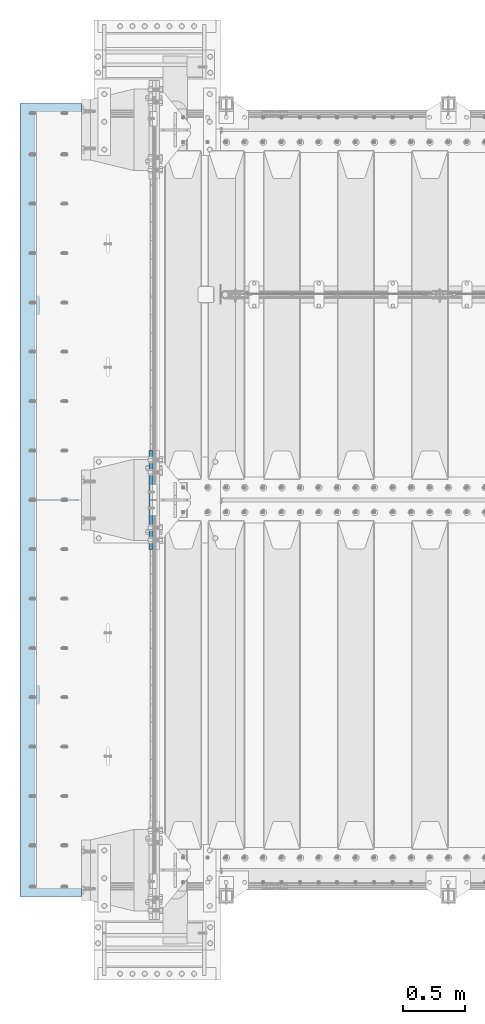
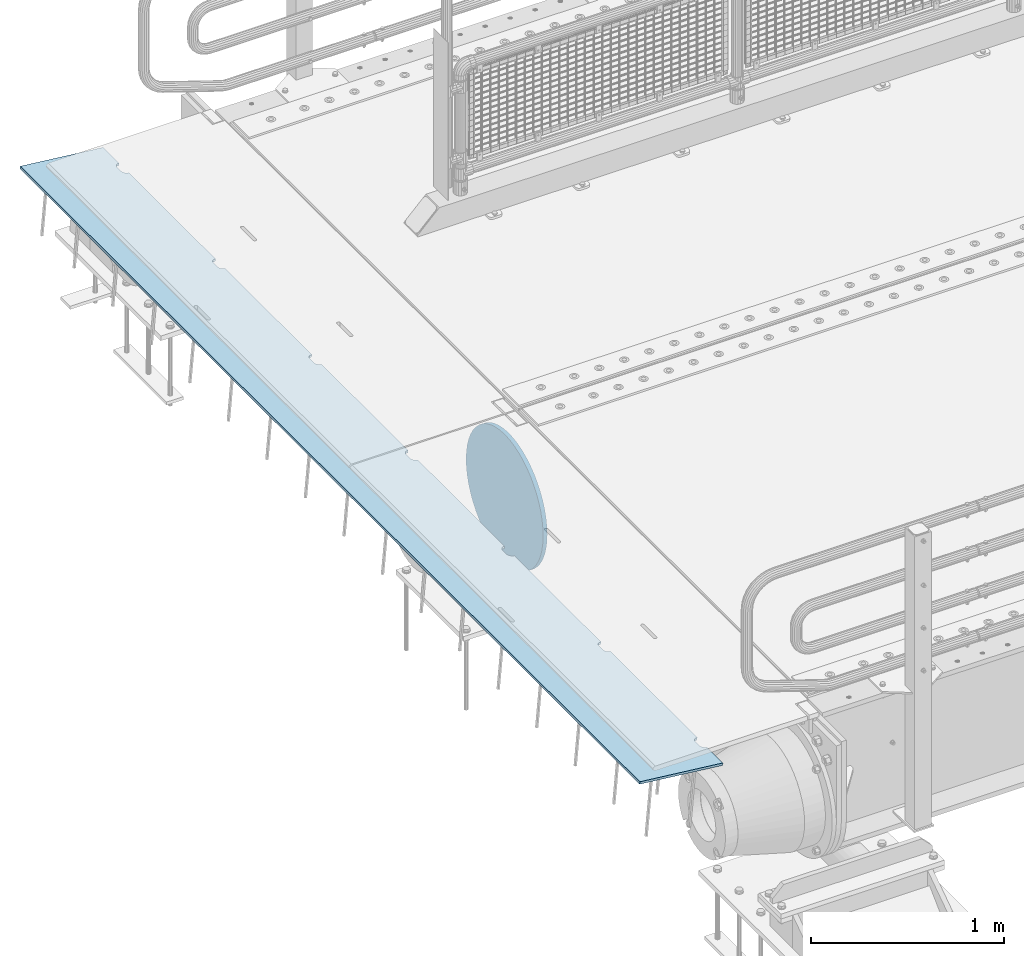
# One storey, part 150 of 193: 2 plates.
"""IFC2X3 building model written with IfcOpenShell, lengths in millimetres."""

from ifc_helpers import new_model, si_unit, frame, origin_with_axes, place, context, subcontext, project, spatial, faceted_brep, material, type_object, element, save


model = new_model("IFC2X3")

# Units and contexts
model_context = context("Model", 3, precision=1e-05, world=origin_with_axes())
body_context = subcontext(model_context, "Body", "Model", "MODEL_VIEW")
ifc_project = project(units=[si_unit("LENGTHUNIT", "METRE", prefix="MILLI"), si_unit("AREAUNIT", "SQUARE_METRE"), si_unit("VOLUMEUNIT", "CUBIC_METRE"), si_unit("MASSUNIT", "GRAM", prefix="KILO"), si_unit("TIMEUNIT", "SECOND"), si_unit("PLANEANGLEUNIT", "RADIAN"), si_unit("SOLIDANGLEUNIT", "STERADIAN"), si_unit("THERMODYNAMICTEMPERATUREUNIT", "DEGREE_CELSIUS"), si_unit("LUMINOUSINTENSITYUNIT", "LUMEN")], contexts=[model_context])

# Site, building, storey
site_placement = place(None, origin_with_axes())
site = spatial("IfcSite", under=ifc_project, at=site_placement, CompositionType="ELEMENT")
building_placement = place(site_placement, origin_with_axes())
building = spatial("IfcBuilding", under=site, at=building_placement, Name="Standard", CompositionType="ELEMENT")
storey_placement = place(building_placement, origin_with_axes())
storey = spatial("IfcBuildingStorey", under=building, at=storey_placement, Name="Undefined", CompositionType="ELEMENT", Elevation=0.0)

# Plates
ifc_material = material(Name="STEEL/S355N")
plate_type_1 = type_object("IfcPlateType", PredefinedType="NOTDEFINED")
plate_1_placement = place(storey_placement, frame((-43074.1812549702, 23785.0, -62.544823504668), z_axis=(-0.994023532708189, -4.00000135296876e-09, 0.109166003967953), x_axis=(0.0, 1.0, 0.0)))
element("IfcPlate", 1, at=plate_1_placement, inside=storey, type_object=plate_type_1, material=ifc_material, context=body_context, shape_type="Brep", body=[
    faceted_brep([(6164.99999999666, -7.5, 7.33479173504747e-05), (6165.00000000327, 7.5, -2.91038304567337e-11), (6165.45576743374, 7.5, 5.20976320983027), (6165.4557674272, -7.49999999999636, 5.20976320983027), (6166.80922142074, 7.5, 10.2609221742096), (6166.80922141419, -7.49999999999727, 10.2609221742168), (6169.01923794974, 7.5, 15.0003178656552), (6169.01923794319, -7.49999999999636, 15.0003178656552), (6172.01866678684, 7.5, 19.2839461443291), (6172.01866678029, -7.49999999999636, 19.2839461443291), (6175.71637180461, 7.5, 22.9816511325917), (6175.71637179805, -7.49999999999727, 22.9816511325917), (6180.0000001072, 7.50000000000091, 25.9810799355255), (6180.00000010065, -7.49999999999636, 25.9810799355328), (6184.73939581627, 7.49999999999909, 28.1910964267227), (6184.73939580972, -7.49999999999727, 28.1910964267227), (6189.79055479144, 7.5, 29.5445503734372), (6189.79055478489, -7.49999999999727, 29.5445503734372), (6195.00000012327, 7.5, 30.0003177623512), (6195.00000011672, -7.49999999999636, 30.0003177623585), (6235.00000012327, 7.50000000000091, 30.0003176033133), (6235.00000011672, -7.49999999999727, 30.0003176033133), (6240.20944545146, 7.49999999999909, 29.54455017297), (6240.20944544491, -7.49999999999727, 29.54455017297), (6245.26060441581, 7.5, 28.1910961860922), (6245.26060440926, -7.49999999999727, 28.1910961860849), (6250.0000001072, 7.5, 25.9810796571983), (6250.00000010065, -7.49999999999636, 25.9810796572056), (6254.2836283858, 7.5, 22.9816508202057), (6254.28362837925, -7.49999999999727, 22.981650820213), (6257.98133337398, 7.5, 19.2839458025337), (6257.98133336743, -7.49999999999636, 19.2839458025264), (6260.98076217681, 7.5, 15.0003175000093), (6260.98076217026, -7.49999999999727, 15.0003175000093), (6263.1907786679, 7.5, 10.2609217909921), (6263.19077866134, -7.49999999999727, 10.2609217909849), (6264.54423261448, 7.5, 5.20976281585172), (6264.54423260793, -7.49999999999636, 5.20976281585172), (6264.99999999672, -7.5, 0.000317484023980796), (6265.00000000327, 7.5, -2.91038304567337e-11), (5264.99999999672, -7.5, 0.000322454179695342), (5264.54423260793, -7.50000000000091, 5.20976778599288), (5264.54423261448, 7.50000000000273, 5.20976778599288), (5265.00000000327, 7.50000000000091, -2.18278728425503e-11), (5263.19077866134, -7.49999999999909, 10.2609267611333), (5263.1907786679, 7.50000000000273, 10.260926761126), (5260.98076217026, -7.50000000000091, 15.0003224701577), (5260.98076217681, 7.50000000000182, 15.0003224701504), (5257.98133336743, -7.50000000000091, 19.2839507726749), (5257.98133337398, 7.50000000000273, 19.2839507726676), (5254.28362837925, -7.5, 22.9816557903541), (5254.2836283858, 7.50000000000273, 22.9816557903541), (5250.00000010065, -7.50000000000091, 25.9810846273467), (5250.0000001072, 7.50000000000273, 25.9810846273467), (5245.26060440926, -7.50000000000091, 28.1911011562406), (5245.26060441581, 7.50000000000182, 28.1911011562333), (5240.20944544491, -7.50000000000091, 29.5445551431112), (5240.20944545146, 7.50000000000273, 29.5445551431039), (5235.00000011672, -7.5, 30.0003225734617), (5235.00000012327, 7.50000000000182, 30.0003225734545), (5195.00000011672, -7.5, 30.0003227324996), (5195.00000012327, 7.50000000000182, 30.0003227324996), (5189.79055478489, -7.50000000000091, 29.5445553435784), (5189.79055479144, 7.50000000000273, 29.5445553435784), (5184.73939580972, -7.50000000000091, 28.1911013968711), (5184.73939581627, 7.50000000000182, 28.1911013968711), (5180.00000010065, -7.50000000000091, 25.9810849056812), (5180.0000001072, 7.50000000000364, 25.9810849056812), (5175.71637179805, -7.5, 22.9816561027474), (5175.71637180461, 7.50000000000273, 22.9816561027401), (5172.01866678029, -7.50000000000091, 19.283951114463), (5172.01866678684, 7.50000000000273, 19.283951114463), (5169.01923794319, -7.50000000000091, 15.0003228357964), (5169.01923794974, 7.50000000000273, 15.0003228357891), (5166.80922141419, -7.5, 10.260927144358), (5166.80922142074, 7.50000000000273, 10.260927144358), (5165.4557674272, -7.5, 5.20976817997871), (5165.45576743374, 7.50000000000364, 5.20976817997143), (5164.9999999967, -7.49999999999909, 0.000191312581591774), (5165.00000000327, 7.50000000000091, -2.18278728425503e-11), (4264.99999999672, -7.5, 0.000327424313582014), (4265.00000000327, 7.5, -2.18278728425503e-11), (4264.54423260793, -7.49999999999909, 5.20977275613404), (4264.54423261448, 7.50000000000273, 5.20977275613404), (4263.19077866134, -7.49999999999909, 10.2609317312817), (4263.1907786679, 7.50000000000273, 10.2609317312817), (4260.98076217026, -7.49999999999818, 15.0003274402916), (4260.98076217681, 7.50000000000273, 15.0003274402916), (4257.98133336743, -7.5, 19.283955742816), (4257.98133337398, 7.50000000000273, 19.283955742816), (4254.28362837925, -7.49999999999909, 22.9816607604953), (4254.2836283858, 7.50000000000364, 22.981660760488), (4250.00000010065, -7.49999999999909, 25.9810895974879), (4250.0000001072, 7.50000000000273, 25.9810895974806), (4245.26060440926, -7.49999999999909, 28.1911061263745), (4245.26060441581, 7.50000000000273, 28.1911061263818), (4240.20944544491, -7.49999999999727, 29.5445601132524), (4240.20944545146, 7.50000000000364, 29.5445601132524), (4235.00000011672, -7.49999999999909, 30.0003275435956), (4235.00000012327, 7.50000000000273, 30.0003275435956), (4195.00000011672, -7.5, 30.0003277026481), (4195.00000012327, 7.50000000000273, 30.0003277026408), (4189.79055478489, -7.49999999999909, 29.5445603137268), (4189.79055479144, 7.50000000000273, 29.5445603137268), (4184.73939580972, -7.49999999999818, 28.1911063670123), (4184.73939581627, 7.50000000000364, 28.1911063670123), (4180.00000010065, -7.49999999999909, 25.9810898758224), (4180.0000001072, 7.50000000000364, 25.9810898758151), (4175.71637179805, -7.49999999999909, 22.9816610728813), (4175.71637180461, 7.50000000000364, 22.9816610728813), (4172.01866678029, -7.49999999999909, 19.2839560846114), (4172.01866678684, 7.50000000000364, 19.2839560846114), (4169.01923794319, -7.49999999999909, 15.0003278059448), (4169.01923794974, 7.50000000000273, 15.0003278059448), (4166.80922141419, -7.5, 10.2609321144992), (4166.80922142074, 7.50000000000364, 10.2609321144919), (4165.4557674272, -7.49999999999909, 5.20977315011987), (4165.45576743374, 7.50000000000273, 5.20977315011987), (4164.99999999671, -7.5, 0.000237874701269902), (4165.00000000327, 7.5, -1.45519152283669e-11), (3264.99999999672, -7.5, 0.000332394462020602), (3265.00000000327, 7.5, -1.45519152283669e-11), (3264.54423260793, -7.49999999999909, 5.20977772627521), (3264.54423261448, 7.50000000000364, 5.20977772627521), (3263.19077866134, -7.49999999999909, 10.2609367014229), (3263.1907786679, 7.50000000000364, 10.2609367014156), (3260.98076217026, -7.49999999999909, 15.0003324104473), (3260.98076217681, 7.50000000000364, 15.00033241044), (3257.98133336743, -7.49999999999818, 19.2839607129645), (3257.98133337398, 7.50000000000455, 19.2839607129572), (3254.28362837925, -7.49999999999909, 22.9816657306292), (3254.2836283858, 7.50000000000182, 22.9816657306292), (3250.00000010065, -7.49999999999818, 25.981094567629), (3250.0000001072, 7.50000000000364, 25.981094567629), (3245.26060440926, -7.49999999999818, 28.1911110965157), (3245.26060441581, 7.50000000000364, 28.1911110965084), (3240.20944544491, -7.49999999999818, 29.5445650833935), (3240.20944545146, 7.50000000000364, 29.5445650833863), (3235.00000011672, -7.49999999999909, 30.0003325137441), (3235.00000012327, 7.50000000000364, 30.0003325137368), (3195.00000011672, -7.49999999999818, 30.000332672782), (3195.00000012327, 7.50000000000455, 30.000332672782), (3189.79055478489, -7.49999999999818, 29.5445652838607), (3189.79055479144, 7.50000000000364, 29.5445652838607), (3184.73939580972, -7.49999999999909, 28.1911113371534), (3184.73939581627, 7.50000000000364, 28.1911113371607), (3180.00000010065, -7.49999999999909, 25.9810948459563), (3180.0000001072, 7.50000000000364, 25.9810948459563), (3175.71637179805, -7.49999999999909, 22.9816660430297), (3175.71637180461, 7.50000000000273, 22.9816660430297), (3172.01866678029, -7.49999999999909, 19.2839610547526), (3172.01866678684, 7.50000000000364, 19.2839610547526), (3169.01923794319, -7.49999999999909, 15.000332776086), (3169.01923794974, 7.50000000000364, 15.0003327760787), (3166.80922141419, -7.49999999999818, 10.260937084633), (3166.80922142074, 7.50000000000182, 10.260937084633), (3165.4557674272, -7.49999999999909, 5.20977812025376), (3165.45576743374, 7.50000000000273, 5.20977812026103), (3164.99999999672, -7.50000000000091, 0.00026446467381902), (3165.00000000327, 7.5, -1.45519152283669e-11), (2264.99999999672, -7.50000000000091, 0.000337364595907275), (2265.00000000327, 7.5, -1.45519152283669e-11), (2264.54423260793, -7.49999999999818, 5.20978269641637), (2264.54423261448, 7.50000000000182, 5.20978269641637), (2263.19077866134, -7.49999999999818, 10.2609416715713), (2263.1907786679, 7.50000000000273, 10.2609416715713), (2260.98076217026, -7.49999999999727, 15.0003373805885), (2260.98076217681, 7.50000000000273, 15.0003373805885), (2257.98133336743, -7.49999999999818, 19.2839656831056), (2257.98133337398, 7.50000000000273, 19.2839656831056), (2254.28362837925, -7.49999999999818, 22.9816707007849), (2254.2836283858, 7.50000000000182, 22.9816707007776), (2250.00000010065, -7.49999999999818, 25.9810995377775), (2250.0000001072, 7.50000000000273, 25.9810995377848), (2245.26060440926, -7.49999999999818, 28.1911160666641), (2245.26060441581, 7.50000000000273, 28.1911160666641), (2240.20944544491, -7.49999999999727, 29.5445700535493), (2240.20944545146, 7.50000000000273, 29.5445700535493), (2235.00000011672, -7.49999999999818, 30.000337483878), (2235.00000012327, 7.50000000000273, 30.000337483878), (2195.00000011672, -7.49999999999818, 30.0003376429304), (2195.00000012327, 7.50000000000273, 30.0003376429231), (2189.79055478489, -7.49999999999727, 29.5445702540092), (2189.79055479144, 7.50000000000182, 29.5445702540092), (2184.73939580972, -7.49999999999727, 28.1911163073019), (2184.73939581627, 7.50000000000273, 28.1911163073019), (2180.00000010065, -7.49999999999909, 25.9810998161047), (2180.0000001072, 7.50000000000273, 25.9810998160974), (2175.71637179805, -7.49999999999818, 22.9816710131636), (2175.71637180461, 7.50000000000182, 22.9816710131636), (2172.01866678029, -7.49999999999909, 19.283966024901), (2172.01866678684, 7.50000000000182, 19.283966024901), (2169.01923794319, -7.49999999999818, 15.0003377462344), (2169.01923794974, 7.50000000000273, 15.0003377462344), (2166.80922141419, -7.49999999999818, 10.2609420547888), (2166.80922142074, 7.50000000000182, 10.2609420547888), (2165.4557674272, -7.49999999999818, 5.2097830904022), (2165.45576743374, 7.50000000000182, 5.2097830904022), (2164.99999999672, -7.50000000000091, 0.000282682995020878), (2165.00000000327, 7.5, -7.27595761418343e-12), (1264.99999999672, -7.5, 0.00034233475162182), (1265.00000000327, 7.5, 0.0), (1264.54423260793, -7.5, 5.20978766657208), (1264.54423261448, 7.50000000000091, 5.20978766656481), (1263.19077866134, -7.49999999999818, 10.2609466417052), (1263.1907786679, 7.50000000000091, 10.260946641698), (1260.98076217026, -7.49999999999909, 15.0003423507296), (1260.98076217681, 7.5, 15.0003423507296), (1257.98133336743, -7.49999999999909, 19.2839706532468), (1257.98133337398, 7.50000000000091, 19.2839706532468), (1254.28362837925, -7.49999999999818, 22.9816756709261), (1254.2836283858, 7.50000000000273, 22.9816756709261), (1250.00000010065, -7.49999999999909, 25.9811045079186), (1250.0000001072, 7.50000000000091, 25.9811045079186), (1245.26060440926, -7.49999999999818, 28.1911210368125), (1245.26060441581, 7.50000000000091, 28.1911210368125), (1240.20944544491, -7.49999999999909, 29.5445750236831), (1240.20944545146, 7.50000000000091, 29.5445750236759), (1235.00000011672, -7.49999999999818, 30.0003424540337), (1235.00000012327, 7.5, 30.0003424540264), (1195.00000011672, -7.49999999999818, 30.0003426130716), (1195.00000012327, 7.5, 30.0003426130716), (1189.79055478489, -7.49999999999818, 29.5445752241503), (1189.79055479144, 7.50000000000091, 29.5445752241503), (1184.73939580972, -7.49999999999909, 28.191121277443), (1184.73939581627, 7.50000000000091, 28.1911212774503), (1180.00000010065, -7.49999999999727, 25.9811047862531), (1180.0000001072, 7.50000000000182, 25.9811047862531), (1175.71637179805, -7.49999999999818, 22.981675983312), (1175.71637180461, 7.50000000000182, 22.981675983312), (1172.01866678029, -7.49999999999909, 19.2839709950422), (1172.01866678684, 7.50000000000182, 19.2839709950422), (1169.01923794319, -7.49999999999818, 15.0003427163683), (1169.01923794974, 7.50000000000182, 15.000342716361), (1166.80922141419, -7.49999999999818, 10.2609470249299), (1166.80922142074, 7.50000000000273, 10.2609470249299), (1165.4557674272, -7.49999999999818, 5.20978806055064), (1165.45576743374, 7.50000000000182, 5.20978806055791), (1164.99999999672, -7.5, 0.000296603444439825), (1165.00000000327, 7.5, 0.0), (264.999999996722, -7.5, 0.000347304885508493), (265.000000003274, 7.50000000000091, 0.0), (264.544232607932, -7.49999999999909, 5.20979263670597), (264.54423261448, 7.50000000000091, 5.20979263670597), (263.190778661345, -7.5, 10.2609516118537), (263.190778667897, 7.5, 10.2609516118537), (260.98076217026, -7.49999999999909, 15.0003473208635), (260.980762176809, 7.50000000000091, 15.0003473208635), (257.981333367428, -7.5, 19.283975623388), (257.981333373977, 7.5, 19.283975623388), (254.283628379246, -7.5, 22.9816806410672), (254.283628385798, 7.50000000000091, 22.9816806410672), (250.000000100648, -7.5, 25.9811094780598), (250.000000107197, 7.50000000000091, 25.9811094780671), (245.260604409257, -7.5, 28.1911260069537), (245.260604415806, 7.5, 28.1911260069537), (240.209445444911, -7.49999999999909, 29.5445799938243), (240.209445451459, 7.5, 29.5445799938243), (235.000000116725, -7.5, 30.0003474241676), (235.000000123273, 7.5, 30.0003474241676), (195.000000116725, -7.5, 30.00034758322), (195.000000123273, 7.5, 30.00034758322), (189.790554784893, -7.5, 29.544580194306), (189.790554791442, 7.5, 29.5445801942988), (184.73939580972, -7.49999999999909, 28.1911262475915), (184.739395816268, 7.50000000000091, 28.1911262475842), (180.000000100648, -7.49999999999909, 25.9811097563943), (180.000000107197, 7.50000000000091, 25.9811097563943), (175.716371798055, -7.49999999999909, 22.9816809534605), (175.716371804607, 7.5, 22.9816809534605), (172.018666780288, -7.49999999999909, 19.2839759651833), (172.018666786837, 7.50000000000091, 19.2839759651833), (169.019237943194, -7.5, 15.0003476865095), (169.019237949742, 7.50000000000091, 15.0003476865095), (166.809221414187, -7.49999999999909, 10.2609519950711), (166.809221420739, 7.5, 10.2609519950784), (165.455767427196, -7.49999999999909, 5.20979303069907), (165.455767433745, 7.50000000000091, 5.2097930306918), (164.999999996722, -7.49999999999909, 0.0), (165.000000003274, 7.50000000000182, 7.27595761418343e-12), (0.0, -7.5, -3.63797880709171e-12), (0.0, 7.5, -3.63797880709171e-12), (1.72946238308214e-06, -7.49999999999909, 500.00244140625), (1.72945874510333e-06, 7.50000000000091, 500.00244140625), (6430.00000001195, -7.5, 500.002380371094), (6430.00000001195, 7.5, 500.002380371094), (6430.0, -7.50000000000091, -2.91038304567337e-11), (6430.0, 7.5, -2.18278728425503e-11)], [[[0, 1, 2, 3]], [[3, 2, 4, 5]], [[5, 4, 6, 7]], [[7, 6, 8, 9]], [[9, 8, 10, 11]], [[11, 10, 12, 13]], [[13, 12, 14, 15]], [[15, 14, 16, 17]], [[17, 16, 18, 19]], [[19, 18, 20, 21]], [[21, 20, 22, 23]], [[23, 22, 24, 25]], [[25, 24, 26, 27]], [[27, 26, 28, 29]], [[29, 28, 30, 31]], [[31, 30, 32, 33]], [[33, 32, 34, 35]], [[35, 34, 36, 37]], [[38, 37, 36, 39]], [[40, 41, 42, 43]], [[44, 45, 42, 41]], [[46, 47, 45, 44]], [[48, 49, 47, 46]], [[50, 51, 49, 48]], [[52, 53, 51, 50]], [[54, 55, 53, 52]], [[56, 57, 55, 54]], [[58, 59, 57, 56]], [[60, 61, 59, 58]], [[62, 63, 61, 60]], [[64, 65, 63, 62]], [[66, 67, 65, 64]], [[68, 69, 67, 66]], [[70, 71, 69, 68]], [[72, 73, 71, 70]], [[74, 75, 73, 72]], [[76, 77, 75, 74]], [[78, 79, 77, 76]], [[80, 81, 79, 78]], [[80, 82, 83, 81]], [[84, 85, 83, 82]], [[86, 87, 85, 84]], [[88, 89, 87, 86]], [[90, 91, 89, 88]], [[92, 93, 91, 90]], [[94, 95, 93, 92]], [[96, 97, 95, 94]], [[98, 99, 97, 96]], [[100, 101, 99, 98]], [[102, 103, 101, 100]], [[104, 105, 103, 102]], [[106, 107, 105, 104]], [[108, 109, 107, 106]], [[110, 111, 109, 108]], [[112, 113, 111, 110]], [[114, 115, 113, 112]], [[116, 117, 115, 114]], [[118, 119, 117, 116]], [[120, 121, 119, 118]], [[120, 122, 123, 121]], [[124, 125, 123, 122]], [[126, 127, 125, 124]], [[128, 129, 127, 126]], [[130, 131, 129, 128]], [[132, 133, 131, 130]], [[134, 135, 133, 132]], [[136, 137, 135, 134]], [[138, 139, 137, 136]], [[140, 141, 139, 138]], [[142, 143, 141, 140]], [[144, 145, 143, 142]], [[146, 147, 145, 144]], [[148, 149, 147, 146]], [[150, 151, 149, 148]], [[152, 153, 151, 150]], [[154, 155, 153, 152]], [[156, 157, 155, 154]], [[158, 159, 157, 156]], [[160, 161, 159, 158]], [[160, 162, 163, 161]], [[164, 165, 163, 162]], [[166, 167, 165, 164]], [[168, 169, 167, 166]], [[170, 171, 169, 168]], [[172, 173, 171, 170]], [[174, 175, 173, 172]], [[176, 177, 175, 174]], [[178, 179, 177, 176]], [[180, 181, 179, 178]], [[182, 183, 181, 180]], [[184, 185, 183, 182]], [[186, 187, 185, 184]], [[188, 189, 187, 186]], [[190, 191, 189, 188]], [[192, 193, 191, 190]], [[194, 195, 193, 192]], [[196, 197, 195, 194]], [[198, 199, 197, 196]], [[200, 201, 199, 198]], [[200, 202, 203, 201]], [[204, 205, 203, 202]], [[206, 207, 205, 204]], [[208, 209, 207, 206]], [[210, 211, 209, 208]], [[212, 213, 211, 210]], [[214, 215, 213, 212]], [[216, 217, 215, 214]], [[218, 219, 217, 216]], [[220, 221, 219, 218]], [[222, 223, 221, 220]], [[224, 225, 223, 222]], [[226, 227, 225, 224]], [[228, 229, 227, 226]], [[230, 231, 229, 228]], [[232, 233, 231, 230]], [[234, 235, 233, 232]], [[236, 237, 235, 234]], [[238, 239, 237, 236]], [[240, 241, 239, 238]], [[240, 242, 243, 241]], [[244, 245, 243, 242]], [[246, 247, 245, 244]], [[248, 249, 247, 246]], [[250, 251, 249, 248]], [[252, 253, 251, 250]], [[254, 255, 253, 252]], [[256, 257, 255, 254]], [[258, 259, 257, 256]], [[260, 261, 259, 258]], [[262, 263, 261, 260]], [[264, 265, 263, 262]], [[266, 267, 265, 264]], [[268, 269, 267, 266]], [[270, 271, 269, 268]], [[272, 273, 271, 270]], [[274, 275, 273, 272]], [[276, 277, 275, 274]], [[278, 279, 277, 276]], [[280, 281, 279, 278]], [[280, 282, 283, 281]], [[282, 284, 285, 283]], [[284, 286, 287, 285]], [[287, 286, 38, 39]], [[34, 32, 30, 28, 26, 24, 22, 20, 18, 16, 14, 12, 10, 8, 6, 4, 2, 1, 43, 42, 45, 47, 49, 51, 53, 55, 57, 59, 61, 63, 65, 67, 69, 71, 73, 75, 77, 79, 81, 83, 85, 87, 89, 91, 93, 95, 97, 99, 101, 103, 105, 107, 109, 111, 113, 115, 117, 119, 121, 123, 125, 127, 129, 131, 133, 135, 137, 139, 141, 143, 145, 147, 149, 151, 153, 155, 157, 159, 161, 163, 165, 167, 169, 171, 173, 175, 177, 179, 181, 183, 185, 187, 189, 191, 193, 195, 197, 199, 201, 203, 205, 207, 209, 211, 213, 215, 217, 219, 221, 223, 225, 227, 229, 231, 233, 235, 237, 239, 241, 243, 245, 247, 249, 251, 253, 255, 257, 259, 261, 263, 265, 267, 269, 271, 273, 275, 277, 279, 281, 283, 285, 287, 39, 36]], [[40, 43, 1, 0]], [[286, 284, 282, 280, 278, 276, 274, 272, 270, 268, 266, 264, 262, 260, 258, 256, 254, 252, 250, 248, 246, 244, 242, 240, 238, 236, 234, 232, 230, 228, 226, 224, 222, 220, 218, 216, 214, 212, 210, 208, 206, 204, 202, 200, 198, 196, 194, 192, 190, 188, 186, 184, 182, 180, 178, 176, 174, 172, 170, 168, 166, 164, 162, 160, 158, 156, 154, 152, 150, 148, 146, 144, 142, 140, 138, 136, 134, 132, 130, 128, 126, 124, 122, 120, 118, 116, 114, 112, 110, 108, 106, 104, 102, 100, 98, 96, 94, 92, 90, 88, 86, 84, 82, 80, 78, 76, 74, 72, 70, 68, 66, 64, 62, 60, 58, 56, 54, 52, 50, 48, 46, 44, 41, 40, 0, 3, 5, 7, 9, 11, 13, 15, 17, 19, 21, 23, 25, 27, 29, 31, 33, 35, 37, 38]]]),
])
plate_type_2 = type_object("IfcPlateType", PredefinedType="NOTDEFINED")
plate_2_placement = place(storey_placement, frame((-42512.5, 27400.0, -114.999999999998), z_axis=(0.0, 0.0, -1.0), x_axis=(0.0, -1.0, 0.0)))
element("IfcPlate", 2, at=plate_2_placement, inside=storey, type_object=plate_type_2, material=ifc_material, context=body_context, shape_type="Brep", body=[
    faceted_brep([(0.0, -12.5, 400.0), (2.91645036198679, -12.5, 448.214672101512), (2.91645036198679, 12.5, 448.214672101512), (0.0, 12.5, 400.0), (11.6232730309493, -12.5, 495.726265714256), (11.6232730309493, 12.5, 495.726265714256), (25.9935029273365, -12.5, 541.8419548161), (25.9935029273365, 12.5, 541.8419548161), (45.8175897403271, -12.5, 585.889268816449), (45.8175897403271, 12.5, 585.889268816449), (70.8064536442362, -12.5, 627.225898691268), (70.8064536442362, 12.5, 627.225898691268), (100.595700733313, -12.5, 665.249063294999), (100.595700733313, 12.5, 665.249063294999), (134.75093670547, -12.5, 699.404299267018), (134.75093670547, 12.5, 699.404299267018), (172.774101309333, -12.5, 729.193546355957), (172.774101309333, 12.5, 729.193546355957), (214.110731184279, -12.5, 754.182410259709), (214.110731184279, 12.5, 754.182410259709), (258.15804518474, -12.5, 774.006497072558), (258.15804518474, 12.5, 774.006497072558), (304.273734286686, -12.5, 788.3767269688), (304.273734286686, 12.5, 788.3767269688), (351.785327899521, -12.5, 797.08354963762), (351.785327899521, 12.5, 797.08354963762), (400.0, -12.5, 800.0), (400.0, 12.5, 800.0), (448.214672103386, -12.5, 797.083549638417), (448.214672103386, 12.5, 797.083549638417), (495.726265716061, -12.5, 788.376726969676), (495.726265716061, 12.5, 788.376726969676), (541.841954817824, -12.5, 774.006497073486), (541.841954817824, 12.5, 774.006497073486), (585.889268818086, -12.5, 754.182410260677), (585.889268818086, 12.5, 754.182410260677), (627.225898692806, -12.5, 729.193546356939), (627.225898692806, 12.5, 729.193546356939), (665.249063296429, -12.5, 699.404299268001), (665.249063296429, 12.5, 699.404299268001), (699.404299268313, -12.5, 665.249063295971), (699.404299268313, 12.5, 665.249063295971), (729.193546357106, -12.5, 627.225898692217), (729.193546357106, 12.5, 627.225898692217), (754.182410260699, -12.5, 585.889268817373), (754.182410260699, 12.5, 585.889268817373), (774.006497073362, -12.5, 541.841954816995), (774.006497073362, 12.5, 541.841954816995), (788.376726969407, -12.5, 495.72626571513), (788.376726969407, 12.5, 495.72626571513), (797.083549638006, -12.5, 448.214672102371), (797.083549638006, 12.5, 448.214672102371), (800.0, -12.5, 400.0), (800.0, 12.5, 400.0), (797.08354963802, -12.5, 351.785327898502), (797.08354963802, 12.5, 351.785327898502), (788.376726969058, -12.5, 304.273734285758), (788.376726969058, 12.5, 304.273734285758), (774.006497072671, -12.5, 258.158045183915), (774.006497072671, 12.5, 258.158045183915), (754.182410259677, -12.5, 214.110731183569), (754.182410259677, 12.5, 214.110731183569), (729.193546355775, -12.5, 172.774101308751), (729.193546355775, 12.5, 172.774101308751), (699.404299266695, -12.5, 134.750936705022), (699.404299266695, 12.5, 134.750936705022), (665.249063294537, -12.5, 100.595700733003), (665.249063294537, 12.5, 100.595700733003), (627.225898690671, -12.5, 70.8064536440688), (627.225898690671, 12.5, 70.8064536440688), (585.889268815728, -12.5, 45.8175897403125), (585.889268815728, 12.5, 45.8175897403125), (541.841954815267, -12.5, 25.9935029274711), (541.841954815267, 12.5, 25.9935029274711), (495.726265713321, -12.5, 11.6232730312295), (495.726265713321, 12.5, 11.6232730312295), (448.214672100487, -12.5, 2.9164503624088), (448.214672100487, 12.5, 2.9164503624088), (400.0, -12.5, -5.6843418860808e-14), (400.0, 12.5, -5.6843418860808e-14), (351.785327896621, -12.5, 2.91645036159025), (351.785327896621, 12.5, 2.91645036159025), (304.27373428395, -12.5, 11.6232730303345), (304.27373428395, 12.5, 11.6232730303345), (258.158045182186, -12.5, 25.9935029265253), (258.158045182186, 12.5, 25.9935029265253), (214.110731181921, -12.5, 45.8175897393376), (214.110731181921, 12.5, 45.8175897393376), (172.774101307201, -12.5, 70.8064536430757), (172.774101307201, 12.5, 70.8064536430757), (134.750936703582, -12.5, 100.59570073201), (134.750936703582, 12.5, 100.59570073201), (100.595700731694, -12.5, 134.750936704037), (100.595700731694, 12.5, 134.750936704037), (70.8064536429047, -12.5, 172.774101307794), (70.8064536429047, 12.5, 172.774101307794), (45.8175897393085, -12.5, 214.110731182634), (45.8175897393085, 12.5, 214.110731182634), (25.9935029266453, -12.5, 258.158045183012), (25.9935029266453, 12.5, 258.158045183012), (11.6232730306001, -12.5, 304.273734284878), (11.6232730306001, 12.5, 304.273734284878), (2.9164503619977, -12.5, 351.78532789764), (2.9164503619977, 12.5, 351.78532789764)], [[[0, 1, 2, 3]], [[1, 4, 5, 2]], [[4, 6, 7, 5]], [[6, 8, 9, 7]], [[8, 10, 11, 9]], [[10, 12, 13, 11]], [[12, 14, 15, 13]], [[14, 16, 17, 15]], [[16, 18, 19, 17]], [[18, 20, 21, 19]], [[20, 22, 23, 21]], [[22, 24, 25, 23]], [[24, 26, 27, 25]], [[26, 28, 29, 27]], [[28, 30, 31, 29]], [[30, 32, 33, 31]], [[32, 34, 35, 33]], [[34, 36, 37, 35]], [[36, 38, 39, 37]], [[38, 40, 41, 39]], [[40, 42, 43, 41]], [[42, 44, 45, 43]], [[44, 46, 47, 45]], [[46, 48, 49, 47]], [[48, 50, 51, 49]], [[50, 52, 53, 51]], [[52, 54, 55, 53]], [[54, 56, 57, 55]], [[56, 58, 59, 57]], [[58, 60, 61, 59]], [[60, 62, 63, 61]], [[62, 64, 65, 63]], [[64, 66, 67, 65]], [[66, 68, 69, 67]], [[68, 70, 71, 69]], [[70, 72, 73, 71]], [[72, 74, 75, 73]], [[74, 76, 77, 75]], [[76, 78, 79, 77]], [[78, 80, 81, 79]], [[80, 82, 83, 81]], [[82, 84, 85, 83]], [[84, 86, 87, 85]], [[86, 88, 89, 87]], [[88, 90, 91, 89]], [[90, 92, 93, 91]], [[92, 94, 95, 93]], [[94, 96, 97, 95]], [[96, 98, 99, 97]], [[98, 100, 101, 99]], [[100, 102, 103, 101]], [[102, 0, 3, 103]], [[5, 7, 9, 11, 13, 15, 17, 19, 21, 23, 25, 27, 29, 31, 33, 35, 37, 39, 41, 43, 45, 47, 49, 51, 53, 55, 57, 59, 61, 63, 65, 67, 69, 71, 73, 75, 77, 79, 81, 83, 85, 87, 89, 91, 93, 95, 97, 99, 101, 103, 3, 2]], [[102, 100, 98, 96, 94, 92, 90, 88, 86, 84, 82, 80, 78, 76, 74, 72, 70, 68, 66, 64, 62, 60, 58, 56, 54, 52, 50, 48, 46, 44, 42, 40, 38, 36, 34, 32, 30, 28, 26, 24, 22, 20, 18, 16, 14, 12, 10, 8, 6, 4, 1, 0]]]),
])

save(model, "model.ifc")
